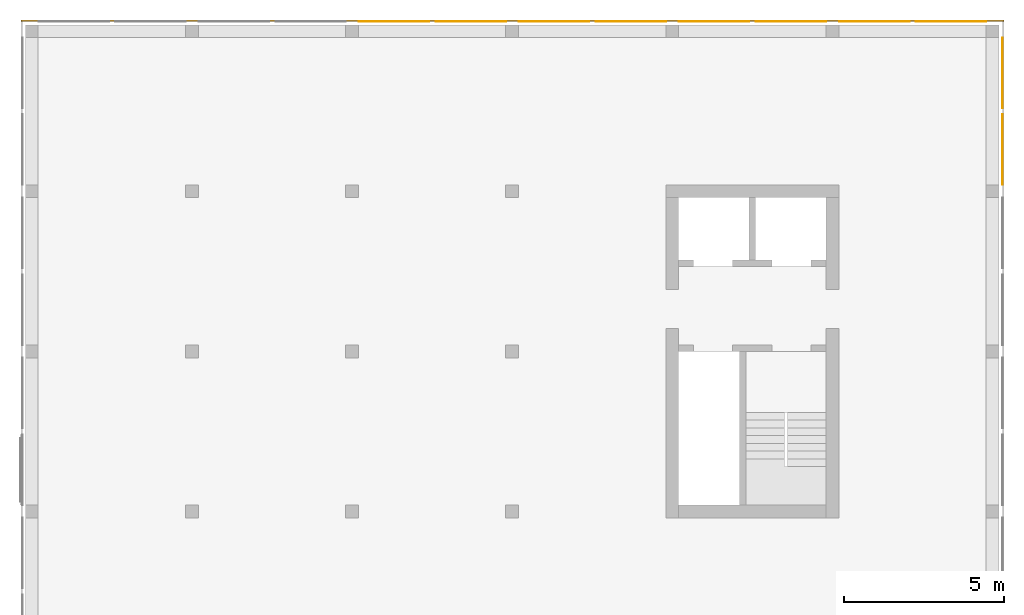
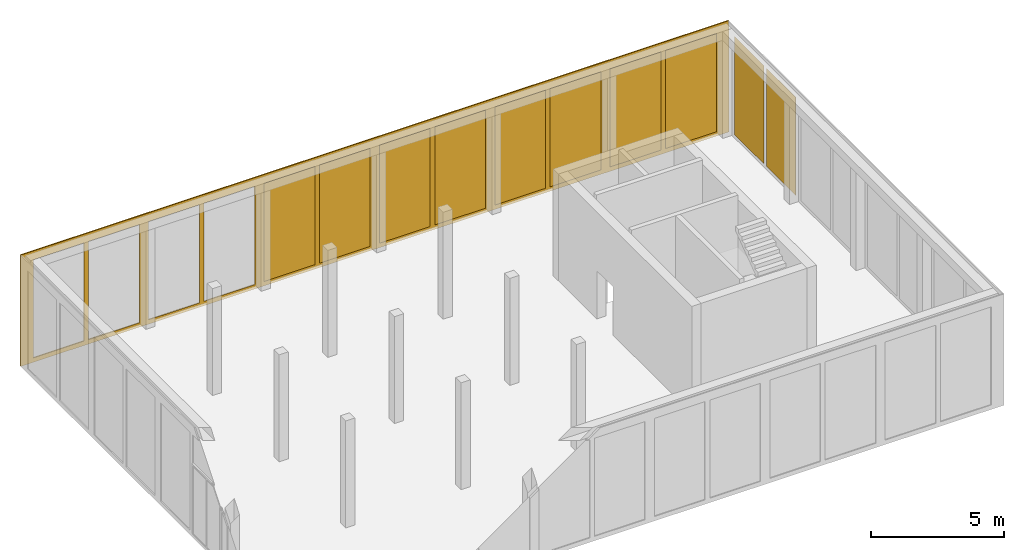
# One storey, part 4 of 5: 11 curtain walls.
"""IFC2X3 building model written with IfcOpenShell, lengths in metres."""

import ifcopenshell
import ifcopenshell.guid

model = None  # the IFC model being written
_history = None  # IfcOwnerHistory: only IFC2X3 demands one
_inside = {}  # id of a spatial element -> (the spatial element, [elements in it])
_under = {}  # id of a project, library or spatial element -> (it, [spatial elements below it])
_declared = {}  # id of a project -> (the project, [libraries it declares])
_typed = {}  # id of a type object -> (the type object, [elements of that type])
_made_of = {}  # id of a material, layer set ... -> (it, [elements and type objects made of it])


def new_model(schema):
    """Start an empty IFC model of exactly this schema.

    Asked for "IFC4X3", IfcOpenShell would pick the latest addendum, in which some entities
    have other attributes; the version numbers below select the first issue.
    IFC2X3 requires an IfcOwnerHistory on every rooted entity: one is made here for all.
    """
    global model, _history
    if schema == "IFC4X3":
        model = ifcopenshell.file(schema_version=(4, 3, 0, 0))
    else:
        model = ifcopenshell.file(schema=schema)
    _inside.clear()
    _under.clear()
    _declared.clear()
    _typed.clear()
    _made_of.clear()
    _history = None
    if model.schema == "IFC2X3":
        org = make("IfcOrganization", Name="unknown")
        user = make(
            "IfcPersonAndOrganization",
            ThePerson=make("IfcPerson", FamilyName="unknown"),
            TheOrganization=org,
        )
        app = make(
            "IfcApplication",
            ApplicationDeveloper=org,
            Version="unknown",
            ApplicationFullName="unknown",
            ApplicationIdentifier="unknown",
        )
        _history = make(
            "IfcOwnerHistory",
            OwningUser=user,
            OwningApplication=app,
            ChangeAction="ADDED",
            CreationDate=0,
        )
    return model


def make(cls, **values):
    """One entity of the class cls with the attributes given. An attribute that is None is left unset."""
    return model.create_entity(
        cls, **{name: value for name, value in values.items() if value is not None}
    )


def entity(cls, *values):
    """Any entity or typed value of the class cls, its attributes in the order of the schema. None: left unset."""
    e = model.create_entity(cls)
    for i, value in enumerate(values):
        if value is not None:
            e[i] = value
    return e


def rooted(cls, **values):
    """An entity with a GlobalId (a new one), such as an element, a storey or a relation."""
    return make(cls, GlobalId=ifcopenshell.guid.new(), OwnerHistory=_history, **values)


def si_unit(unit_type, name, prefix=None):
    """IfcSIUnit, for example si_unit("LENGTHUNIT", "METRE", prefix="MILLI")."""
    return make("IfcSIUnit", UnitType=unit_type, Prefix=prefix, Name=name)


def converted_unit(unit_type, name, factor, base, dimensions=None, offset=None):
    """IfcConversionBasedUnit, such as the inch: factor (a typed value) times the base unit."""
    return make(
        "IfcConversionBasedUnit"
        if offset is None
        else "IfcConversionBasedUnitWithOffset",
        ConversionOffset=offset,
        Dimensions=None
        if dimensions is None
        else entity("IfcDimensionalExponents", *dimensions),
        UnitType=unit_type,
        Name=name,
        ConversionFactor=make(
            "IfcMeasureWithUnit", ValueComponent=factor, UnitComponent=base
        ),
    )


def assignment(units):
    """IfcUnitAssignment: the units of a project."""
    return None if units is None else make("IfcUnitAssignment", Units=units)


def point(xyz):
    """IfcCartesianPoint."""
    return None if xyz is None else make("IfcCartesianPoint", Coordinates=xyz)


def direction(xyz):
    """IfcDirection."""
    return None if xyz is None else make("IfcDirection", DirectionRatios=xyz)


def frame(location, z_axis=None, x_axis=None):
    """IfcAxis2Placement3D, a coordinate frame: its origin and axes. An axis left out is left unset."""
    return make(
        "IfcAxis2Placement3D",
        Location=point(location),
        Axis=direction(z_axis),
        RefDirection=direction(x_axis),
    )


def origin():
    """The frame at (0, 0, 0) with its axes left unset."""
    return frame((0.0, 0.0, 0.0))


def place(relative_to, where):
    """IfcLocalPlacement: puts the frame where relative to a parent placement (None: the world)."""
    return make(
        "IfcLocalPlacement", PlacementRelTo=relative_to, RelativePlacement=where
    )


def context(
    kind, dimensions, precision=None, world=None, true_north=None, identifier=None
):
    """IfcGeometricRepresentationContext, for example the 3D "Model" context."""
    return make(
        "IfcGeometricRepresentationContext",
        ContextIdentifier=identifier,
        ContextType=kind,
        CoordinateSpaceDimension=dimensions,
        Precision=precision,
        WorldCoordinateSystem=world,
        TrueNorth=true_north,
    )


def subcontext(parent, identifier, kind, view, scale=None):
    """IfcGeometricRepresentationSubContext, for example "Body" below "Model"."""
    return make(
        "IfcGeometricRepresentationSubContext",
        ContextIdentifier=identifier,
        ContextType=kind,
        ParentContext=parent,
        TargetScale=scale,
        TargetView=view,
    )


def project(units=None, contexts=None):
    """IfcProject with its units and contexts."""
    return rooted(
        "IfcProject",
        Name="project",
        RepresentationContexts=contexts,
        UnitsInContext=assignment(units),
    )


def spatial(cls, under=None, at=None, **own):
    """A site, building, storey or space (cls), placed at a placement, below another one or the project."""
    s = rooted(cls, ObjectPlacement=at, **own)
    if under is not None:
        _under.setdefault(under.id(), (under, []))[1].append(s)
    return s


def faces_of(points, faces, orient=None, outer=None):
    """IfcFace entities. A face is a list of loops; a loop is a list of indices into points, from 0.

    orient and outer hold one flag for each loop. By default every Orientation is true, the
    first loop of a face is its IfcFaceOuterBound and the others are IfcFaceBound.
    """
    made = []
    for i, loops in enumerate(faces):
        bounds = []
        for j, loop in enumerate(loops):
            is_outer = j == 0 if outer is None else outer[i][j]
            bounds.append(
                make(
                    "IfcFaceOuterBound" if is_outer else "IfcFaceBound",
                    Bound=make("IfcPolyLoop", Polygon=[points[k] for k in loop]),
                    Orientation=True if orient is None else orient[i][j],
                )
            )
        made.append(make("IfcFace", Bounds=bounds))
    return made


def faceted_brep(points, faces, orient=None, outer=None, voids=None):
    """IfcFacetedBrep: a solid bounded by flat faces; with voids (closed shells), ...WithVoids."""
    shared = [point(p) for p in points]
    hull = make("IfcClosedShell", CfsFaces=faces_of(shared, faces, orient, outer))
    if voids is None:
        return make("IfcFacetedBrep", Outer=hull)
    return make(
        "IfcFacetedBrepWithVoids",
        Outer=hull,
        Voids=[
            make(cls, CfsFaces=faces_of(shared, fs, o, b)) for cls, fs, o, b in voids
        ],
    )


def shape(context_of_items, identifier, shape_type, items):
    """IfcShapeRepresentation: the items that make up one representation, for example the "Body"."""
    return make(
        "IfcShapeRepresentation",
        ContextOfItems=context_of_items,
        RepresentationIdentifier=identifier,
        RepresentationType=shape_type,
        Items=items,
    )


def material(Name=None, Category=None):
    """IfcMaterial."""
    return make("IfcMaterial", Name=Name, Category=Category)


def made_of(thing, what):
    """Note that an element or type object is made of a material, layer set ...; save() writes the relation."""
    if what is not None:
        _made_of.setdefault(what.id(), (what, []))[1].append(thing)
    return thing


def element(
    cls,
    number,
    at=None,
    inside=None,
    cuts=None,
    type_object=None,
    material=None,
    context=None,
    identifier="Body",
    shape_type=None,
    held_by="IfcProductDefinitionShape",
    body=None,
    shapes=None,
    **own,
):
    """One element of the class cls, such as IfcWall. Its Tag is "e" and its number.

    at: its placement. inside: the storey or other place that contains it. cuts: it is an
    opening in that element (IfcRelVoidsElement). A single representation is given by context,
    identifier, shape_type and body (its items); several are given by shapes. held_by: the class
    of the entity that holds the representations. save() writes the other relations.
    """
    e = rooted(cls, Tag="e%d" % number, ObjectPlacement=at, **own)
    if body is not None:
        shapes = [shape(context, identifier, shape_type, body)]
    if shapes is not None:
        e.Representation = make(held_by, Representations=shapes)
    if inside is not None:
        _inside.setdefault(inside.id(), (inside, []))[1].append(e)
    if cuts is not None:
        rooted(
            "IfcRelVoidsElement", RelatingBuildingElement=cuts, RelatedOpeningElement=e
        )
    if type_object is not None:
        _typed.setdefault(type_object.id(), (type_object, []))[1].append(e)
    return made_of(e, material)


def aggregate(whole, parts):
    """IfcRelAggregates: a whole, such as a stair, and the parts it consists of."""
    return rooted("IfcRelAggregates", RelatingObject=whole, RelatedObjects=parts)


def save(model, path):
    """Write the relations noted so far, then the file.

    IfcRelAggregates (storeys below a building ...), IfcRelContainedInSpatialStructure (elements
    in a storey), IfcRelDefinesByType, IfcRelAssociatesMaterial and IfcRelDeclares: one each for
    every whole, place, type object, material and project.
    """
    for whole, parts in _under.values():
        aggregate(whole, parts)
    for where, things in _inside.values():
        rooted(
            "IfcRelContainedInSpatialStructure",
            RelatedElements=things,
            RelatingStructure=where,
        )
    for kind, things in _typed.values():
        rooted("IfcRelDefinesByType", RelatedObjects=things, RelatingType=kind)
    for what, things in _made_of.values():
        rooted("IfcRelAssociatesMaterial", RelatedObjects=things, RelatingMaterial=what)
    for by, libraries in _declared.values():
        rooted("IfcRelDeclares", RelatingContext=by, RelatedDefinitions=libraries)
    model.write(path)


model = new_model("IFC2X3")

# Units and contexts
model_context = context("Model", 3, precision=1e-05, world=origin())
body_context = subcontext(model_context, "Body", "Model", "MODEL_VIEW")
ifc_project = project(units=[si_unit("LENGTHUNIT", "METRE"), si_unit("AREAUNIT", "SQUARE_METRE"), si_unit("VOLUMEUNIT", "CUBIC_METRE"), si_unit("MASSUNIT", "GRAM", prefix="KILO"), converted_unit("PLANEANGLEUNIT", "DEGREE", entity("IfcPlaneAngleMeasure", 0.0174532925199433), si_unit("PLANEANGLEUNIT", "RADIAN"), dimensions=[0, 0, 0, 0, 0, 0, 0])], contexts=[model_context])

# Site, building, storey
site_placement = place(None, origin())
site = spatial("IfcSite", under=ifc_project, at=site_placement, CompositionType="ELEMENT")
building_placement = place(site_placement, origin())
building = spatial("IfcBuilding", under=site, at=building_placement, CompositionType="ELEMENT")
storey_placement = place(building_placement, frame((0.0, 0.0, -0.2)))
storey = spatial("IfcBuildingStorey", under=building, at=storey_placement, Name="Erdgeschoss", CompositionType="ELEMENT", Elevation=-0.2)

# Curtain walls
ifc_material_1 = material(Name="ALU")
curtain_wall_1_placement = place(storey_placement, frame((-0.139330706017223, 20.5, -0.2)))
element("IfcCurtainWall", 1, at=curtain_wall_1_placement, inside=storey, material=ifc_material_1, Name="Profil SN", context=body_context, shape_type="Brep", body=[
    faceted_brep([(0.0, 0.05, 5.1), (30.7, 0.05, 5.1), (30.7, 0.0, 5.1), (0.0, 0.0, 5.1), (30.7, 0.05, 0.0), (30.7, 0.0, 0.0), (30.15, 0.0, 0.2), (30.15, 0.05, 0.2), (30.15, 0.05, 4.7), (30.15, 0.0, 4.7), (27.95, 0.0, 0.2), (27.95, 0.05, 0.2), (27.95, 0.0, 4.7), (27.95, 0.05, 4.7), (27.75, 0.05, 0.2), (27.75, 0.05, 4.7), (27.75, 0.0, 4.7), (27.75, 0.0, 0.2), (25.55, 0.05, 0.2), (25.55, 0.0, 0.2), (25.55, 0.0, 4.7), (25.55, 0.05, 4.7), (25.15, 0.0, 0.2), (25.15, 0.05, 0.2), (25.15, 0.05, 4.7), (25.15, 0.0, 4.7), (22.95, 0.0, 0.2), (22.95, 0.05, 0.2), (22.95, 0.0, 4.7), (22.95, 0.05, 4.7), (22.75, 0.05, 0.2), (22.75, 0.05, 4.7), (22.75, 0.0, 4.7), (22.75, 0.0, 0.2), (20.55, 0.05, 0.2), (20.55, 0.0, 0.2), (20.55, 0.0, 4.7), (20.55, 0.05, 4.7), (20.15, 0.0, 0.2), (20.15, 0.05, 0.2), (20.15, 0.05, 4.7), (20.15, 0.0, 4.7), (17.95, 0.05, 0.2), (17.95, 0.0, 0.2), (17.75, 0.0, 0.2), (15.55, 0.0, 0.2), (15.55, 0.05, 0.2), (17.75, 0.05, 0.2), (12.95, 0.05, 0.2), (15.15, 0.05, 0.2), (15.15, 0.0, 0.2), (12.95, 0.0, 0.2), (12.75, 0.0, 0.2), (10.55, 0.0, 0.2), (10.55, 0.05, 0.2), (12.75, 0.05, 0.2), (7.95, 0.05, 0.2), (10.15, 0.05, 0.2), (10.15, 0.0, 0.2), (7.95, 0.0, 0.2), (7.75, 0.0, 0.2), (5.55, 0.0, 0.2), (5.55, 0.05, 0.2), (7.75, 0.05, 0.2), (2.95, 0.05, 0.2), (5.15, 0.05, 0.2), (5.15, 0.0, 0.2), (2.95, 0.0, 0.2), (2.75, 0.0, 0.2), (0.550000000000002, 0.0, 0.2), (0.550000000000002, 0.05, 0.2), (2.75, 0.05, 0.2), (0.0, 0.0, 0.0), (0.0, 0.05, 0.0), (5.15, 0.05, 4.7), (5.15, 0.0, 4.7), (5.55, 0.0, 4.7), (5.55, 0.05, 4.7), (0.550000000000002, 0.0, 4.7), (0.550000000000007, 0.05, 4.7), (15.15, 0.05, 4.7), (15.15, 0.0, 4.7), (15.55, 0.0, 4.7), (15.55, 0.05, 4.7), (10.15, 0.05, 4.7), (10.15, 0.0, 4.7), (10.55, 0.0, 4.7), (10.55, 0.05, 4.7), (7.75, 0.05, 4.7), (7.75, 0.0, 4.7), (7.95, 0.0, 4.7), (7.95, 0.05, 4.7), (2.75, 0.05, 4.7), (2.75, 0.0, 4.7), (2.95, 0.0, 4.7), (2.95, 0.05, 4.7), (17.75, 0.05, 4.7), (17.75, 0.0, 4.7), (17.95, 0.0, 4.7), (17.95, 0.05, 4.7), (12.75, 0.05, 4.7), (12.75, 0.0, 4.7), (12.95, 0.0, 4.7), (12.95, 0.05, 4.7)], [[[0, 1, 2, 3]], [[4, 5, 2, 1]], [[6, 7, 8, 9]], [[6, 10, 11, 7]], [[10, 12, 13, 11]], [[14, 15, 16, 17]], [[18, 14, 17, 19]], [[18, 19, 20, 21]], [[22, 23, 24, 25]], [[22, 26, 27, 23]], [[26, 28, 29, 27]], [[30, 31, 32, 33]], [[34, 30, 33, 35]], [[34, 35, 36, 37]], [[38, 39, 40, 41]], [[42, 39, 38, 43]], [[44, 45, 46, 47]], [[48, 49, 50, 51]], [[52, 53, 54, 55]], [[56, 57, 58, 59]], [[60, 61, 62, 63]], [[64, 65, 66, 67]], [[68, 69, 70, 71]], [[72, 73, 0, 3]], [[4, 73, 72, 5]], [[66, 65, 74, 75]], [[62, 61, 76, 77]], [[70, 69, 78, 79]], [[50, 49, 80, 81]], [[46, 45, 82, 83]], [[58, 57, 84, 85]], [[54, 53, 86, 87]], [[63, 88, 89, 60]], [[59, 90, 91, 56]], [[71, 92, 93, 68]], [[67, 94, 95, 64]], [[47, 96, 97, 44]], [[43, 98, 99, 42]], [[55, 100, 101, 52]], [[51, 102, 103, 48]], [[78, 93, 92, 79]], [[74, 95, 94, 75]], [[76, 89, 88, 77]], [[84, 91, 90, 85]], [[86, 101, 100, 87]], [[80, 103, 102, 81]], [[82, 97, 96, 83]], [[40, 99, 98, 41]], [[31, 37, 36, 32]], [[28, 25, 24, 29]], [[15, 21, 20, 16]], [[12, 9, 8, 13]], [[2, 5, 72, 3], [10, 6, 9, 12], [20, 19, 17, 16], [28, 26, 22, 25], [36, 35, 33, 32], [98, 43, 38, 41], [97, 82, 45, 44], [81, 102, 51, 50], [101, 86, 53, 52], [85, 90, 59, 58], [89, 76, 61, 60], [75, 94, 67, 66], [93, 78, 69, 68]], [[0, 73, 4, 1], [70, 79, 92, 71], [95, 74, 65, 64], [77, 88, 63, 62], [91, 84, 57, 56], [87, 100, 55, 54], [103, 80, 49, 48], [83, 96, 47, 46], [99, 40, 39, 42], [31, 30, 34, 37], [24, 23, 27, 29], [15, 14, 18, 21], [8, 7, 11, 13]]], orient=[[False], [False], [False], [False], [False], [False], [False], [False], [False], [False], [False], [False], [False], [False], [False], [False], [False], [False], [False], [False], [False], [False], [False], [False], [False], [False], [False], [False], [False], [False], [False], [False], [False], [False], [False], [False], [False], [False], [False], [False], [False], [False], [False], [False], [False], [False], [False], [False], [False], [False], [False], [False], [False, False, False, False, False, False, False, False, False, False, False, False, False], [False, False, False, False, False, False, False, False, False, False, False, False, False]]),
])
ifc_material_2 = material(Name="VSG")
curtain_wall_2_placement = place(storey_placement, frame((30.5106692939828, 15.4, 0.0)))
element("IfcCurtainWall", 2, at=curtain_wall_2_placement, inside=storey, material=ifc_material_2, context=body_context, shape_type="Brep", body=[
    faceted_brep([(0.0, 1.81898940354586e-15, 0.0), (0.0, 1.81898940354586e-15, 4.5), (0.005, 1.81898940354586e-15, 4.5), (0.005, 1.81898940354586e-15, 0.0), (0.005, 2.20000000000001, 4.5), (0.005, 2.20000000000001, 0.0), (0.0, 2.20000000000001, 4.5), (0.0, 2.20000000000001, 0.0)], [[[0, 1, 2, 3]], [[3, 2, 4, 5]], [[5, 4, 6, 7]], [[7, 6, 1, 0]], [[6, 4, 2, 1]], [[0, 3, 5, 7]]], orient=[[False], [False], [False], [False], [False], [False]]),
])
ifc_material_3 = material(Name="VSG")
curtain_wall_3_placement = place(storey_placement, frame((30.5106692939828, 17.8, 0.0)))
element("IfcCurtainWall", 3, at=curtain_wall_3_placement, inside=storey, material=ifc_material_3, context=body_context, shape_type="Brep", body=[
    faceted_brep([(0.0, 0.0, 0.0), (0.0, 0.0, 4.5), (0.005, 0.0, 4.5), (0.005, 0.0, 0.0), (0.005, 2.2, 4.5), (0.005, 2.2, 0.0), (0.0, 2.2, 4.5), (0.0, 2.2, 0.0)], [[[0, 1, 2, 3]], [[3, 2, 4, 5]], [[5, 4, 6, 7]], [[7, 6, 1, 0]], [[6, 4, 2, 1]], [[0, 3, 5, 7]]], orient=[[False], [False], [False], [False], [False], [False]]),
])
ifc_material_4 = material(Name="VSG")
curtain_wall_4_placement = place(storey_placement, frame((10.4106692939828, 20.5, 0.0)))
element("IfcCurtainWall", 4, at=curtain_wall_4_placement, inside=storey, material=ifc_material_4, context=body_context, shape_type="Brep", body=[
    faceted_brep([(2.2, 0.0, 0.0), (2.2, 0.0, 4.5), (2.2, 0.005, 4.5), (2.2, 0.005, 0.0), (0.0, 0.005, 4.5), (0.0, 0.005, 0.0), (0.0, 0.0, 4.5), (0.0, 0.0, 0.0)], [[[0, 1, 2, 3]], [[3, 2, 4, 5]], [[5, 4, 6, 7]], [[7, 6, 1, 0]], [[6, 4, 2, 1]], [[0, 3, 5, 7]]], orient=[[False], [False], [False], [False], [False], [False]]),
])
ifc_material_5 = material(Name="VSG")
curtain_wall_5_placement = place(storey_placement, frame((12.8106692939828, 20.5, 0.0)))
element("IfcCurtainWall", 5, at=curtain_wall_5_placement, inside=storey, material=ifc_material_5, context=body_context, shape_type="Brep", body=[
    faceted_brep([(2.2, 0.0, 0.0), (2.2, 0.0, 4.5), (2.2, 0.005, 4.5), (2.2, 0.005, 0.0), (0.0, 0.005, 4.5), (0.0, 0.005, 0.0), (0.0, 0.0, 4.5), (0.0, 0.0, 0.0)], [[[0, 1, 2, 3]], [[3, 2, 4, 5]], [[5, 4, 6, 7]], [[7, 6, 1, 0]], [[6, 4, 2, 1]], [[0, 3, 5, 7]]], orient=[[False], [False], [False], [False], [False], [False]]),
])
ifc_material_6 = material(Name="VSG")
curtain_wall_6_placement = place(storey_placement, frame((15.4106692939828, 20.5, 0.0)))
element("IfcCurtainWall", 6, at=curtain_wall_6_placement, inside=storey, material=ifc_material_6, context=body_context, shape_type="Brep", body=[
    faceted_brep([(2.2, 0.0, 0.0), (2.2, 0.0, 4.5), (2.2, 0.005, 4.5), (2.2, 0.005, 0.0), (-1.81898940354586e-15, 0.005, 4.5), (-1.81898940354586e-15, 0.005, 0.0), (-1.81898940354586e-15, 0.0, 4.5), (-1.81898940354586e-15, 0.0, 0.0)], [[[0, 1, 2, 3]], [[3, 2, 4, 5]], [[5, 4, 6, 7]], [[7, 6, 1, 0]], [[6, 4, 2, 1]], [[0, 3, 5, 7]]], orient=[[False], [False], [False], [False], [False], [False]]),
])
ifc_material_7 = material(Name="VSG")
curtain_wall_7_placement = place(storey_placement, frame((17.8106692939828, 20.5, 0.0)))
element("IfcCurtainWall", 7, at=curtain_wall_7_placement, inside=storey, material=ifc_material_7, context=body_context, shape_type="Brep", body=[
    faceted_brep([(2.2, 0.0, 0.0), (2.2, 0.0, 4.5), (2.2, 0.005, 4.5), (2.2, 0.005, 0.0), (-3.63797880709171e-15, 0.005, 4.5), (-3.63797880709171e-15, 0.005, 0.0), (-3.63797880709171e-15, 0.0, 4.5), (-3.63797880709171e-15, 0.0, 0.0)], [[[0, 1, 2, 3]], [[3, 2, 4, 5]], [[5, 4, 6, 7]], [[7, 6, 1, 0]], [[6, 4, 2, 1]], [[0, 3, 5, 7]]], orient=[[False], [False], [False], [False], [False], [False]]),
])
ifc_material_8 = material(Name="VSG")
curtain_wall_8_placement = place(storey_placement, frame((22.8106692939828, 20.5, 0.0)))
element("IfcCurtainWall", 8, at=curtain_wall_8_placement, inside=storey, material=ifc_material_8, context=body_context, shape_type="Brep", body=[
    faceted_brep([(2.2, 0.0, 0.0), (2.2, 0.0, 4.5), (2.2, 0.005, 4.5), (2.2, 0.005, 0.0), (-3.63797880709171e-15, 0.005, 4.5), (-3.63797880709171e-15, 0.005, 0.0), (-3.63797880709171e-15, 0.0, 4.5), (-3.63797880709171e-15, 0.0, 0.0)], [[[0, 1, 2, 3]], [[3, 2, 4, 5]], [[5, 4, 6, 7]], [[7, 6, 1, 0]], [[6, 4, 2, 1]], [[0, 3, 5, 7]]], orient=[[False], [False], [False], [False], [False], [False]]),
])
ifc_material_9 = material(Name="VSG")
curtain_wall_9_placement = place(storey_placement, frame((25.4106692939828, 20.5, 0.0)))
element("IfcCurtainWall", 9, at=curtain_wall_9_placement, inside=storey, material=ifc_material_9, context=body_context, shape_type="Brep", body=[
    faceted_brep([(2.2, 0.0, 0.0), (2.2, 0.0, 4.5), (2.2, 0.005, 4.5), (2.2, 0.005, 0.0), (-3.63797880709171e-15, 0.005, 4.5), (-3.63797880709171e-15, 0.005, 0.0), (-3.63797880709171e-15, 0.0, 4.5), (-3.63797880709171e-15, 0.0, 0.0)], [[[0, 1, 2, 3]], [[3, 2, 4, 5]], [[5, 4, 6, 7]], [[7, 6, 1, 0]], [[6, 4, 2, 1]], [[0, 3, 5, 7]]], orient=[[False], [False], [False], [False], [False], [False]]),
])
ifc_material_10 = material(Name="VSG")
curtain_wall_10_placement = place(storey_placement, frame((27.8106692939828, 20.5, 0.0)))
element("IfcCurtainWall", 10, at=curtain_wall_10_placement, inside=storey, material=ifc_material_10, context=body_context, shape_type="Brep", body=[
    faceted_brep([(2.2, 0.0, 0.0), (2.2, 0.0, 4.5), (2.2, 0.005, 4.5), (2.2, 0.005, 0.0), (-3.63797880709171e-15, 0.005, 4.5), (-3.63797880709171e-15, 0.005, 0.0), (-3.63797880709171e-15, 0.0, 4.5), (-3.63797880709171e-15, 0.0, 0.0)], [[[0, 1, 2, 3]], [[3, 2, 4, 5]], [[5, 4, 6, 7]], [[7, 6, 1, 0]], [[6, 4, 2, 1]], [[0, 3, 5, 7]]], orient=[[False], [False], [False], [False], [False], [False]]),
])
ifc_material_11 = material(Name="VSG")
curtain_wall_11_placement = place(storey_placement, frame((20.4106692939828, 20.5, 0.0)))
element("IfcCurtainWall", 11, at=curtain_wall_11_placement, inside=storey, material=ifc_material_11, context=body_context, shape_type="Brep", body=[
    faceted_brep([(2.2, 0.0, 0.0), (2.2, 0.0, 4.5), (2.2, 0.005, 4.5), (2.2, 0.005, 0.0), (-3.63797880709171e-15, 0.005, 4.5), (-3.63797880709171e-15, 0.005, 0.0), (-3.63797880709171e-15, 0.0, 4.5), (-3.63797880709171e-15, 0.0, 0.0)], [[[0, 1, 2, 3]], [[3, 2, 4, 5]], [[5, 4, 6, 7]], [[7, 6, 1, 0]], [[6, 4, 2, 1]], [[0, 3, 5, 7]]], orient=[[False], [False], [False], [False], [False], [False]]),
])

save(model, "model.ifc")
